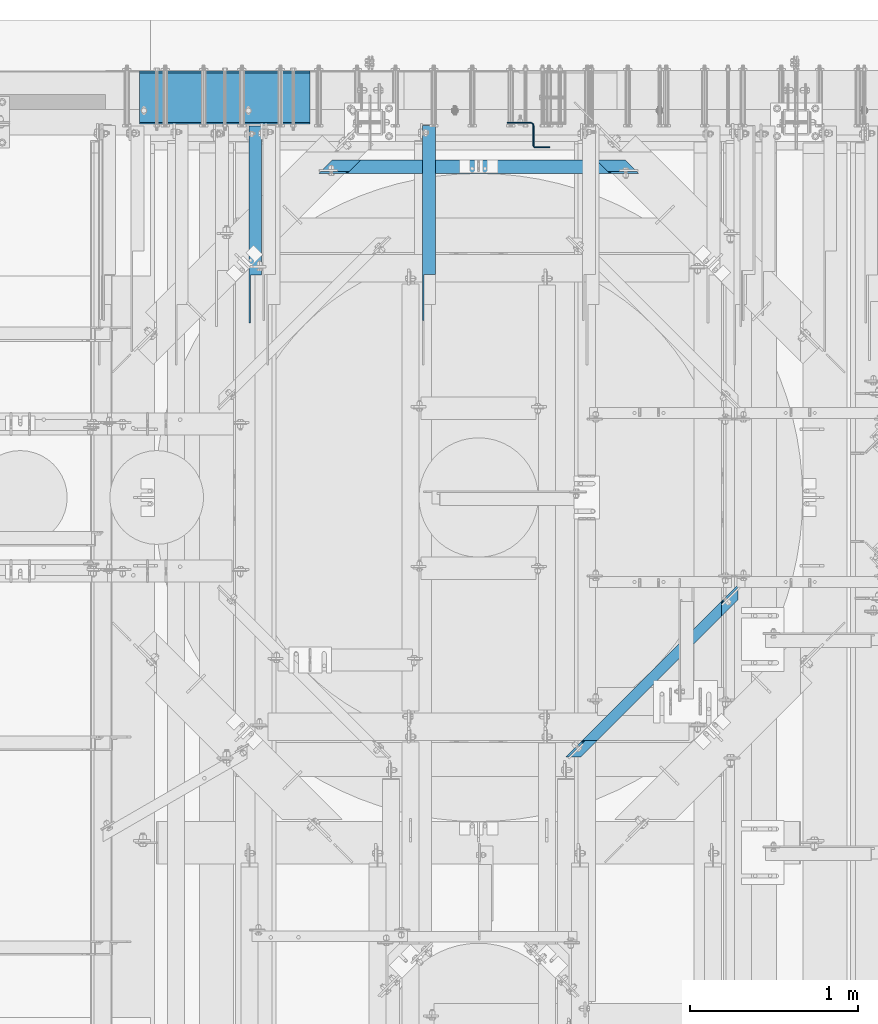
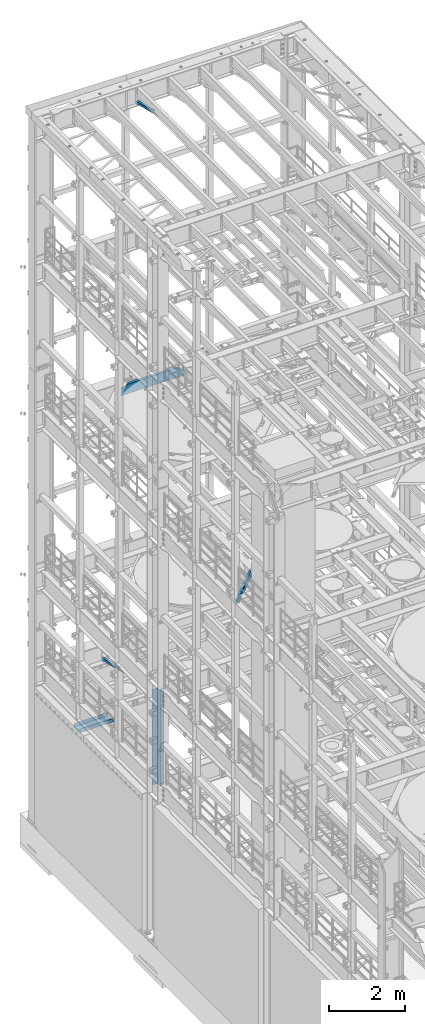
# One storey, part 1059 of 1876: 6 beams, 6 elements without a shape of their own.
"""IFC2X3 building model written with IfcOpenShell, lengths in millimetres."""

from ifc_helpers import new_model, si_unit, frame, origin_with_axes, place, context, subcontext, project, spatial, faceted_brep, material, type_object, element, aggregate, save


model = new_model("IFC2X3")

# Units and contexts
model_context = context("Model", 3, precision=1e-05, world=origin_with_axes())
body_context = subcontext(model_context, "Body", "Model", "MODEL_VIEW")
ifc_project = project(units=[si_unit("LENGTHUNIT", "METRE", prefix="MILLI"), si_unit("AREAUNIT", "SQUARE_METRE"), si_unit("VOLUMEUNIT", "CUBIC_METRE"), si_unit("MASSUNIT", "GRAM", prefix="KILO"), si_unit("TIMEUNIT", "SECOND"), si_unit("PLANEANGLEUNIT", "RADIAN"), si_unit("SOLIDANGLEUNIT", "STERADIAN"), si_unit("THERMODYNAMICTEMPERATUREUNIT", "DEGREE_CELSIUS"), si_unit("LUMINOUSINTENSITYUNIT", "LUMEN")], contexts=[model_context])

# Site, building, storey
site_placement = place(None, origin_with_axes())
site = spatial("IfcSite", under=ifc_project, at=site_placement, CompositionType="ELEMENT")
building_placement = place(site_placement, origin_with_axes())
building = spatial("IfcBuilding", under=site, at=building_placement, Name="Undefined", CompositionType="ELEMENT")
storey_placement = place(building_placement, origin_with_axes())
storey = spatial("IfcBuildingStorey", under=building, at=storey_placement, Name="Undefined", CompositionType="ELEMENT", Elevation=0.0)

# Assembly, beam
assembly_1_placement = place(storey_placement, origin_with_axes())
assembly_1 = element("IfcElementAssembly", 1, at=assembly_1_placement, inside=storey, AssemblyPlace="NOTDEFINED", PredefinedType="RIGID_FRAME")
ifc_material = material(Name="STEEL/A36")
beam_type_1 = type_object("IfcBeamType", Name="L3X3X3/8", PredefinedType="NOTDEFINED")
beam_1_placement = place(assembly_1_placement, frame((2892.425, 12840.8509533049, 22213.431722183), z_axis=(1.0, 0.0, 0.0), x_axis=(0.0, 0.970296005691371, -0.241920774923053)))
beam_1 = element("IfcBeam", 2, at=beam_1_placement, type_object=beam_type_1, material=ifc_material, ObjectType="L3X3X3/8", context=body_context, shape_type="Brep", body=[
    faceted_brep([(0.0, 38.1000000000004, -38.1), (0.0, 38.1000000000004, 38.1), (871.989692018896, 38.1000000003733, 38.1000000000004), (871.989692018896, 38.1000000003733, -38.1000000000004), (-38.2028763666676, 28.5750000000298, 38.1000000000004), (871.9896920189, 28.5750000003572, 38.1000000000004), (-38.2028763666676, 28.5750000000298, -28.5749999999998), (871.9896920189, 28.5750000003572, -28.5749999999998), (-305.623010913256, -38.1000000001623, -28.5749999999998), (871.989692018928, -38.0999999997366, -28.5749999999998), (-305.623010913256, -38.1000000001623, -38.1000000000004), (871.989692018928, -38.0999999997366, -38.1000000000004)], [[[0, 1, 2, 3]], [[1, 4, 5, 2]], [[4, 6, 7, 5]], [[6, 8, 9, 7]], [[8, 10, 11, 9]], [[10, 0, 3, 11]], [[5, 7, 9, 11, 3, 2]], [[10, 8, 6, 4, 1, 0]]]),
])
aggregate(assembly_1, [beam_1])

assembly_2_placement = place(storey_placement, origin_with_axes())
assembly_2 = element("IfcElementAssembly", 3, at=assembly_2_placement, inside=storey, AssemblyPlace="NOTDEFINED", PredefinedType="RIGID_FRAME")
beam_2_placement = place(assembly_2_placement, frame((1857.375, 12840.0279763324, 4779.41022141264), z_axis=(1.0, 0.0, 0.0), x_axis=(0.0, 0.972828834357878, -0.231525504085172)))
beam_2 = element("IfcBeam", 4, at=beam_2_placement, type_object=beam_type_1, material=ifc_material, ObjectType="L3X3X3/8", context=body_context, shape_type="Brep", body=[
    faceted_brep([(0.0, 38.1000000000004, -38.1), (0.0, 38.1000000000004, 38.1), (867.661079933076, 38.1000000002077, 38.1000000000004), (867.661079933076, 38.1000000002077, -38.1000000000004), (-40.0223495126247, 28.5749999999825, 38.1000000000004), (867.661079933077, 28.5750000002117, 38.1000000000004), (-40.0223495126247, 28.5749999999825, -28.5749999999998), (867.661079933077, 28.5750000002117, -28.5749999999998), (-320.178796151862, -38.1000000000677, -28.5749999999998), (867.661079933077, -38.0999999997684, -28.5749999999998), (-320.178796151862, -38.1000000000677, -38.1000000000004), (867.661079933077, -38.0999999997684, -38.1000000000004)], [[[0, 1, 2, 3]], [[1, 4, 5, 2]], [[4, 6, 7, 5]], [[6, 8, 9, 7]], [[8, 10, 11, 9]], [[10, 0, 3, 11]], [[5, 7, 9, 11, 3, 2]], [[10, 8, 6, 4, 1, 0]]]),
])
aggregate(assembly_2, [beam_2])

assembly_3_placement = place(storey_placement, origin_with_axes())
assembly_3 = element("IfcElementAssembly", 5, at=assembly_3_placement, inside=storey, Name="BEAM", AssemblyPlace="NOTDEFINED", PredefinedType="RIGID_FRAME")
beam_type_2 = type_object("IfcBeamType", Name="C12X30", PredefinedType="NOTDEFINED")
beam_3_placement = place(assembly_3_placement, frame((2208.30597027501, 13450.8875070029, 13157.2), z_axis=(0.0, 0.0, -1.0), x_axis=(1.0, 0.0, 0.0)))
beam_3 = element("IfcBeam", 6, at=beam_3_placement, type_object=beam_type_2, material=ifc_material, Name="BEAM", ObjectType="C12X30", context=body_context, shape_type="Brep", body=[
    faceted_brep([(38.5182363484219, 26.9874999999993, -112.712499999998), (25.818236348422, 39.6875, -112.712499999998), (179.60513132235, 39.6875, -112.712499999998), (192.30513132235, 26.9874999999993, -112.712499999998), (186.478321690983, 39.6875, -113.679229922585), (199.178321690983, 26.9874999999993, -113.679229922585), (192.305131131617, 39.6875, -116.432243823063), (205.005131131617, 26.9874999999993, -116.432243823063), (196.198480727076, 39.6875, -120.552420291217), (208.898480727075, 26.9874999999993, -120.552420291217), (197.565643294752, 39.6875, -125.412499809263), (210.265643294751, 26.9874999999993, -125.412499809263), (276.940643294752, -39.6875, -146.311937500001), (210.265643294751, 26.9874999999993, -135.2038825), (197.565643294752, 39.6875, -152.4), (276.940643294752, -39.6875, -152.4), (25.818236348422, 39.6875, 152.4), (105.193236348422, -39.6875, 152.4), (1853.59482157434, -39.6875, 152.4), (1932.96982157434, 39.6875, 152.4), (105.193236348422, -39.6875, 146.311937500001), (1853.59482157434, -39.6875, 146.311937500001), (38.5182363484219, 26.9874999999993, 135.2038825), (1920.26982157434, 26.9874999999993, 135.2038825), (1920.26982157434, 26.9874999999993, -112.712499999998), (1932.96982157434, 39.6875, -112.712499999998), (1766.48292659577, 26.9874999999993, -112.712499999998), (1779.18292659577, 39.6875, -112.712499999998), (1759.60973622714, 26.9874999999993, -113.679229922585), (1772.30973622714, 39.6875, -113.679229922585), (1753.7829267865, 26.9874999999993, -116.432243823063), (1766.4829267865, 39.6875, -116.432243823063), (1749.88957719105, 26.9874999999993, -120.552420291217), (1762.58957719105, 39.6875, -120.552420291217), (1748.52241462337, 26.9874999999993, -125.412499809263), (1761.22241462337, 39.6875, -125.412499809263), (1748.52241462337, 26.9874999999993, -135.2038825), (1681.84741462337, -39.6875, -146.311937500001), (1681.84741462337, -39.6875, -152.4), (1761.22241462337, 39.6875, -152.4)], [[[0, 1, 2, 3]], [[3, 2, 4, 5]], [[5, 4, 6, 7]], [[7, 6, 8, 9]], [[9, 8, 10, 11]], [[12, 13, 11, 10, 14, 15]], [[16, 17, 18, 19]], [[17, 20, 21, 18]], [[20, 22, 23, 21]], [[19, 18, 21, 23, 24, 25]], [[25, 24, 26, 27]], [[27, 26, 28, 29]], [[29, 28, 30, 31]], [[31, 30, 32, 33]], [[33, 32, 34, 35]], [[35, 34, 36, 37, 38, 39]], [[38, 37, 12, 15]], [[39, 38, 15, 14]], [[6, 4, 2, 1, 16, 19, 25, 27, 29, 31, 33, 35, 39, 14, 10, 8]], [[22, 20, 17, 16, 1, 0]], [[36, 34, 32, 30, 28, 26, 24, 23, 22, 0, 3, 5, 7, 9, 11, 13]], [[37, 36, 13, 12]]]),
])
aggregate(assembly_3, [beam_3])

assembly_4_placement = place(storey_placement, origin_with_axes())
assembly_4 = element("IfcElementAssembly", 7, at=assembly_4_placement, inside=storey, Name="BEAM", AssemblyPlace="NOTDEFINED", PredefinedType="RIGID_FRAME")
beam_type_3 = type_object("IfcBeamType", Name="C8X18.75", PredefinedType="NOTDEFINED")
beam_4_placement = place(assembly_4_placement, frame((3755.91883979114, 9938.5544966836, 8051.8), z_axis=(0.0, 0.0, 1.0), x_axis=(0.707305809668414, 0.706907696668603, 0.0)))
beam_4 = element("IfcBeam", 8, at=beam_4_placement, type_object=beam_type_3, material=ifc_material, Name="BEAM", ObjectType="C8X18.75", context=body_context, shape_type="Brep", body=[
    faceted_brep([(-23.567323479856, 19.0499999999947, -88.9012700000003), (27.2612858286848, -31.7499999999927, -97.3645500000002), (1349.86603784282, -31.749999999598, -97.3645500000002), (1400.63744463734, 19.0500000004204, -88.9012700000003), (27.2612858286848, -31.7499999999927, -101.6), (1349.86603784282, -31.749999999598, -101.6), (1275.29771249639, 31.7500000003829, 101.6), (1211.83345400329, -31.7499999996398, 101.6), (1211.83345400329, -31.7499999996398, 97.3645500000002), (1262.60486079777, 19.0500000003785, 88.9012700000003), (1262.60486079781, 19.0500000003785, 85.7249998092684), (1275.29771249644, 31.7500000003838, 85.7249998092684), (1263.97163866019, 19.0500000003794, 80.8649202912229), (1276.66449035882, 31.7500000003838, 80.8649202912229), (1267.86389270766, 19.0500000003813, 76.7447438230693), (1280.55674440629, 31.7500000003847, 76.7447438230693), (1273.68906254486, 19.0500000003822, 73.9917299225908), (1286.38191424349, 31.7500000003865, 73.9917299225908), (1280.56031886937, 19.050000000384, 73.0250000000033), (1293.253170568, 31.7500000003884, 73.0250000000033), (1413.33029633597, 31.7500000004247, 73.0250000000033), (1400.63744463734, 19.0500000004204, 73.0250000000033), (1413.33029633597, 31.7500000004247, -101.6), (-36.2744758069912, 31.7499999999918, -101.6), (103.45255281678, 19.0500000000329, 73.9917299206654), (90.7454004896463, 31.75000000003, 73.9917299206654), (83.8702744428447, 31.7500000000282, 73.0249999980779), (96.5774267699799, 19.0500000000302, 73.0249999980779), (109.281003246128, 19.0500000000338, 76.7447438211439), (96.5738509189905, 31.7500000000318, 76.7447438211439), (113.175449315189, 19.0500000000357, 80.8649202892975), (100.468296988052, 31.7500000000327, 80.8649202892975), (114.542996913191, 19.0500000000366, 85.724999807343), (101.835844586056, 31.7500000000327, 85.724999807343), (-36.2744758069912, 31.7499999999918, 73.0249999980779), (101.83584458595, 31.7500000000327, 101.6), (165.371606221586, -31.7499999999518, 101.6), (165.371606221586, -31.7499999999518, 97.3645500000002), (114.542996913078, 19.0500000000366, 88.9012700000003), (-23.567323479856, 19.0499999999947, 73.0249999980779)], [[[0, 1, 2, 3]], [[1, 4, 5, 2]], [[6, 7, 8, 9, 10, 11]], [[11, 10, 12, 13]], [[13, 12, 14, 15]], [[15, 14, 16, 17]], [[17, 16, 18, 19]], [[20, 19, 18, 21]], [[3, 2, 5, 22, 20, 21]], [[4, 23, 22, 5]], [[24, 25, 26, 27]], [[28, 29, 25, 24]], [[30, 31, 29, 28]], [[32, 33, 31, 30]], [[6, 11, 13, 15, 17, 19, 20, 22, 23, 34, 26, 25, 29, 31, 33, 35]], [[7, 6, 35, 36]], [[8, 7, 36, 37]], [[9, 8, 37, 38]], [[36, 35, 33, 32, 38, 37]], [[30, 28, 24, 27, 39, 0, 3, 21, 18, 16, 14, 12, 10, 9, 38, 32]], [[23, 4, 1, 0, 39, 34]], [[27, 26, 34, 39]]]),
])
aggregate(assembly_4, [beam_4])

assembly_5_placement = place(storey_placement, origin_with_axes())
assembly_5 = element("IfcElementAssembly", 9, at=assembly_5_placement, inside=storey, Name="BENT PLATE", AssemblyPlace="NOTDEFINED", PredefinedType="RIGID_FRAME")
beam_type_4 = type_object("IfcBeamType", PredefinedType="NOTDEFINED")
beam_5_placement = place(assembly_5_placement, frame((1676.4, 13709.65, 2549.52490081787), z_axis=(1.0, 0.0, 0.0), x_axis=(0.0, 0.0, -1.0)))
beam_5 = element("IfcBeam", 10, at=beam_5_placement, type_object=beam_type_4, material=ifc_material, Name="BENT PLATE", context=body_context, shape_type="Brep", body=[
    faceted_brep([(0.0, -4.76250000000073, -508.0), (0.0, -4.76250000000073, 508.0), (0.0, 4.76250000000073, 508.0), (0.0, 4.76250000000073, -508.0), (101.599998474122, 4.76250000000073, 508.0), (101.599998474122, 4.76250000000073, -508.0), (111.124998474122, -4.76250000000073, -508.0), (111.124998474122, -4.76250000000073, 508.0), (101.599998474122, 301.624987792969, 508.0), (101.599998474122, 301.624987792969, -508.0), (111.124998474122, 311.149987792971, -508.0), (111.124998474122, 311.149987792971, 508.0), (0.0, 301.624987792969, 508.0), (0.0, 301.624987792969, -508.0), (0.0, 311.149987792971, 508.0), (0.0, 311.149987792971, -508.0)], [[[0, 1, 2, 3]], [[3, 2, 4, 5]], [[1, 0, 6, 7]], [[5, 4, 8, 9]], [[7, 6, 10, 11]], [[9, 8, 12, 13]], [[8, 4, 2, 1, 7, 11, 14, 12]], [[11, 10, 15, 14]], [[10, 6, 0, 3, 5, 9, 13, 15]], [[14, 15, 13, 12]]]),
])
aggregate(assembly_5, [beam_5])

assembly_6_placement = place(storey_placement, origin_with_axes())
assembly_6 = element("IfcElementAssembly", 11, at=assembly_6_placement, inside=storey, Name="BENT PLATE", AssemblyPlace="NOTDEFINED", PredefinedType="RIGID_FRAME")
beam_type_5 = type_object("IfcBeamType", PredefinedType="NOTDEFINED")
beam_6_placement = place(assembly_6_placement, frame((3359.1495555724, 13712.8250188271, 1524.0), z_axis=(0.0, 0.0, 1.0), x_axis=(1.0, 0.0, 0.0)))
beam_6 = element("IfcBeam", 12, at=beam_6_placement, type_object=beam_type_5, material=ifc_material, Name="BENT PLATE", context=body_context, shape_type="Brep", body=[
    faceted_brep([(-9.88620740827173e-10, 3.17500000000291, -1524.0), (-9.88620740827173e-10, 3.17500000000291, 1524.0), (139.699995674332, 3.17500000233849, 1524.0), (139.699995674332, 3.17500000233849, -1524.0), (9.877112461254e-10, -3.17499999999563, 1524.0), (9.877112461254e-10, -3.17499999999563, -1524.0), (139.699995674433, -3.17499999766005, -1524.0), (139.699995674433, -3.17499999766005, 1524.0), (149.224994891685, 0.622784366969427, 1524.0), (149.224994891685, 0.622784366969427, -1524.0), (146.049995120879, -4.87647707938777, -1524.0), (146.049995120879, -4.87647707938777, 1524.0), (150.698517608313, -9.52499898567839, -1524.0), (150.698517608313, -9.52499898567839, 1524.0), (156.197778657743, -6.34999852737201, 1524.0), (156.197778657743, -6.34999852737201, -1524.0), (152.399995483898, -15.8749982194149, -1524.0), (152.399995483898, -15.8749982194149, 1524.0), (158.749995483898, -15.8749974256571, 1524.0), (158.749995483899, -15.8749974256571, -1524.0), (158.750010565149, -136.52499865716, 1524.0), (158.750010565148, -136.52499865716, -1524.0), (152.400010565148, -136.524999450916, -1524.0), (152.400010565148, -136.524999450916, 1524.0), (159.600749622438, -139.69999845545, 1524.0), (159.600749622438, -139.69999845545, -1524.0), (154.101488705282, -142.874999142861, -1524.0), (154.101488705282, -142.874999142861, 1524.0), (158.750011844602, -147.523521120045, -1524.0), (158.750011844602, -147.523521120045, 1524.0), (161.925011157192, -142.024259409134, 1524.0), (161.925011157192, -142.024259409134, -1524.0), (165.100011961915, -149.224997672669, -1524.0), (165.100011961915, -149.224997672669, 1524.0), (165.100011168165, -142.87499767267, 1524.0), (165.100011168165, -142.87499767267, -1524.0), (254.000017462373, -142.874986560088, 1524.0), (254.000017462373, -142.874986560088, -1524.0), (254.000018256123, -149.224986560088, 1524.0), (254.000018256123, -149.224986560088, -1524.0)], [[[0, 1, 2, 3]], [[4, 5, 6, 7]], [[5, 4, 1, 0]], [[3, 2, 8, 9]], [[7, 6, 10, 11]], [[10, 12, 13, 11]], [[8, 14, 15, 9]], [[12, 16, 17, 13]], [[14, 18, 19, 15]], [[19, 18, 20, 21]], [[17, 16, 22, 23]], [[21, 20, 24, 25]], [[23, 22, 26, 27]], [[26, 28, 29, 27]], [[24, 30, 31, 25]], [[28, 32, 33, 29]], [[30, 34, 35, 31]], [[35, 34, 36, 37]], [[34, 30, 24, 20, 18, 14, 8, 2, 1, 4, 7, 11, 13, 17, 23, 27, 29, 33, 38, 36]], [[33, 32, 39, 38]], [[32, 28, 26, 22, 16, 12, 10, 6, 5, 0, 3, 9, 15, 19, 21, 25, 31, 35, 37, 39]], [[38, 39, 37, 36]]]),
])
aggregate(assembly_6, [beam_6])

save(model, "model.ifc")
